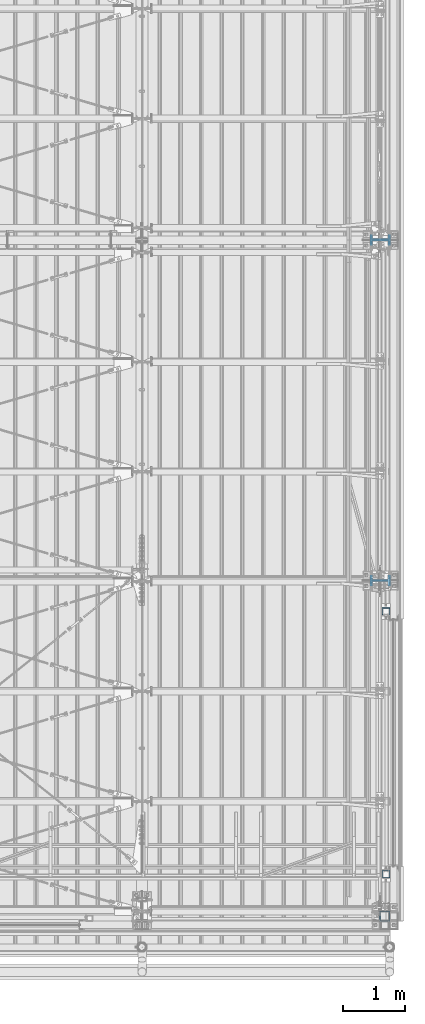
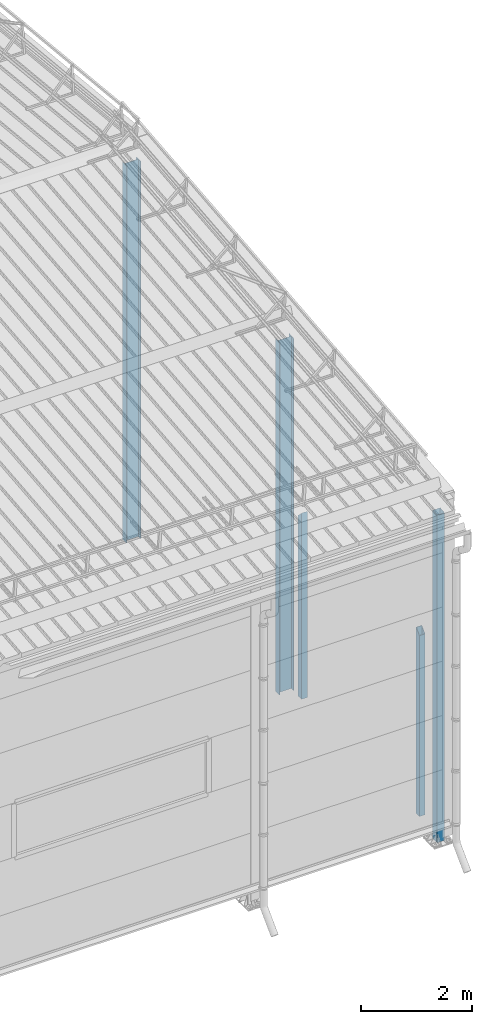
# One storey, part 236 of 709: 5 columns, 1 opening, 5 elements without a shape of their own.
"""IFC4 building model written with IfcOpenShell, lengths in millimetres."""

import ifcopenshell
import ifcopenshell.guid

model = None  # the IFC model being written
_history = None  # IfcOwnerHistory: only IFC2X3 demands one
_inside = {}  # id of a spatial element -> (the spatial element, [elements in it])
_under = {}  # id of a project, library or spatial element -> (it, [spatial elements below it])
_declared = {}  # id of a project -> (the project, [libraries it declares])
_typed = {}  # id of a type object -> (the type object, [elements of that type])
_made_of = {}  # id of a material, layer set ... -> (it, [elements and type objects made of it])


def new_model(schema):
    """Start an empty IFC model of exactly this schema.

    Asked for "IFC4X3", IfcOpenShell would pick the latest addendum, in which some entities
    have other attributes; the version numbers below select the first issue.
    IFC2X3 requires an IfcOwnerHistory on every rooted entity: one is made here for all.
    """
    global model, _history
    if schema == "IFC4X3":
        model = ifcopenshell.file(schema_version=(4, 3, 0, 0))
    else:
        model = ifcopenshell.file(schema=schema)
    _inside.clear()
    _under.clear()
    _declared.clear()
    _typed.clear()
    _made_of.clear()
    _history = None
    if model.schema == "IFC2X3":
        org = make("IfcOrganization", Name="unknown")
        user = make(
            "IfcPersonAndOrganization",
            ThePerson=make("IfcPerson", FamilyName="unknown"),
            TheOrganization=org,
        )
        app = make(
            "IfcApplication",
            ApplicationDeveloper=org,
            Version="unknown",
            ApplicationFullName="unknown",
            ApplicationIdentifier="unknown",
        )
        _history = make(
            "IfcOwnerHistory",
            OwningUser=user,
            OwningApplication=app,
            ChangeAction="ADDED",
            CreationDate=0,
        )
    return model


def make(cls, **values):
    """One entity of the class cls with the attributes given. An attribute that is None is left unset."""
    return model.create_entity(
        cls, **{name: value for name, value in values.items() if value is not None}
    )


def rooted(cls, **values):
    """An entity with a GlobalId (a new one), such as an element, a storey or a relation."""
    return make(cls, GlobalId=ifcopenshell.guid.new(), OwnerHistory=_history, **values)


def si_unit(unit_type, name, prefix=None):
    """IfcSIUnit, for example si_unit("LENGTHUNIT", "METRE", prefix="MILLI")."""
    return make("IfcSIUnit", UnitType=unit_type, Prefix=prefix, Name=name)


def assignment(units):
    """IfcUnitAssignment: the units of a project."""
    return None if units is None else make("IfcUnitAssignment", Units=units)


def point(xyz):
    """IfcCartesianPoint."""
    return None if xyz is None else make("IfcCartesianPoint", Coordinates=xyz)


def direction(xyz):
    """IfcDirection."""
    return None if xyz is None else make("IfcDirection", DirectionRatios=xyz)


def frame(location, z_axis=None, x_axis=None):
    """IfcAxis2Placement3D, a coordinate frame: its origin and axes. An axis left out is left unset."""
    return make(
        "IfcAxis2Placement3D",
        Location=point(location),
        Axis=direction(z_axis),
        RefDirection=direction(x_axis),
    )


def origin_with_axes():
    """The frame at (0, 0, 0) with the z axis (0, 0, 1) and the x axis (1, 0, 0) written out."""
    return frame((0.0, 0.0, 0.0), z_axis=(0.0, 0.0, 1.0), x_axis=(1.0, 0.0, 0.0))


def place(relative_to, where):
    """IfcLocalPlacement: puts the frame where relative to a parent placement (None: the world)."""
    return make(
        "IfcLocalPlacement", PlacementRelTo=relative_to, RelativePlacement=where
    )


def context(
    kind, dimensions, precision=None, world=None, true_north=None, identifier=None
):
    """IfcGeometricRepresentationContext, for example the 3D "Model" context."""
    return make(
        "IfcGeometricRepresentationContext",
        ContextIdentifier=identifier,
        ContextType=kind,
        CoordinateSpaceDimension=dimensions,
        Precision=precision,
        WorldCoordinateSystem=world,
        TrueNorth=true_north,
    )


def subcontext(parent, identifier, kind, view, scale=None):
    """IfcGeometricRepresentationSubContext, for example "Body" below "Model"."""
    return make(
        "IfcGeometricRepresentationSubContext",
        ContextIdentifier=identifier,
        ContextType=kind,
        ParentContext=parent,
        TargetScale=scale,
        TargetView=view,
    )


def project(units=None, contexts=None):
    """IfcProject with its units and contexts."""
    return rooted(
        "IfcProject",
        Name="project",
        RepresentationContexts=contexts,
        UnitsInContext=assignment(units),
    )


def spatial(cls, under=None, at=None, **own):
    """A site, building, storey or space (cls), placed at a placement, below another one or the project."""
    s = rooted(cls, ObjectPlacement=at, **own)
    if under is not None:
        _under.setdefault(under.id(), (under, []))[1].append(s)
    return s


def point_list(points):
    """IfcCartesianPointList2D or 3D."""
    cls = (
        "IfcCartesianPointList2D" if len(points[0]) == 2 else "IfcCartesianPointList3D"
    )
    return make(cls, CoordList=points)


def line(*indices):
    """IfcLineIndex: a straight run through numbered points of an indexed curve."""
    return model.create_entity("IfcLineIndex", indices)


def indexed_curve(points, segments=None, self_intersect=None):
    """IfcIndexedPolyCurve: lines and arcs through numbered points (the first is 1)."""
    return make(
        "IfcIndexedPolyCurve",
        Points=point_list(points),
        Segments=segments,
        SelfIntersect=self_intersect,
    )


def outline(outer, holes=None, kind="AREA"):
    """IfcArbitraryClosedProfileDef: a profile drawn as a closed curve; with holes, ...WithVoids."""
    if holes is None:
        return make("IfcArbitraryClosedProfileDef", ProfileType=kind, OuterCurve=outer)
    return make(
        "IfcArbitraryProfileDefWithVoids",
        ProfileType=kind,
        OuterCurve=outer,
        InnerCurves=holes,
    )


def extrude(swept, where, along, depth):
    """IfcExtrudedAreaSolid: the profile swept, set in the frame where, extruded along a direction by depth."""
    return make(
        "IfcExtrudedAreaSolid",
        SweptArea=swept,
        Position=where,
        ExtrudedDirection=direction(along),
        Depth=depth,
    )


def polygons(points, faces, closed=None, point_numbers=None):
    """IfcPolygonalFaceSet: a face is its outer loop, then its inner loops; points numbered from 1."""
    made = []
    for loops in faces:
        if len(loops) == 1:
            made.append(make("IfcIndexedPolygonalFace", CoordIndex=loops[0]))
        else:
            made.append(
                make(
                    "IfcIndexedPolygonalFaceWithVoids",
                    CoordIndex=loops[0],
                    InnerCoordIndices=loops[1:],
                )
            )
    return make(
        "IfcPolygonalFaceSet",
        Coordinates=point_list(points),
        Closed=closed,
        Faces=made,
        PnIndex=point_numbers,
    )


def shape(context_of_items, identifier, shape_type, items):
    """IfcShapeRepresentation: the items that make up one representation, for example the "Body"."""
    return make(
        "IfcShapeRepresentation",
        ContextOfItems=context_of_items,
        RepresentationIdentifier=identifier,
        RepresentationType=shape_type,
        Items=items,
    )


def material(Name=None, Category=None):
    """IfcMaterial."""
    return make("IfcMaterial", Name=Name, Category=Category)


def made_of(thing, what):
    """Note that an element or type object is made of a material, layer set ...; save() writes the relation."""
    if what is not None:
        _made_of.setdefault(what.id(), (what, []))[1].append(thing)
    return thing


def element(
    cls,
    number,
    at=None,
    inside=None,
    cuts=None,
    type_object=None,
    material=None,
    context=None,
    identifier="Body",
    shape_type=None,
    held_by="IfcProductDefinitionShape",
    body=None,
    shapes=None,
    **own,
):
    """One element of the class cls, such as IfcWall. Its Tag is "e" and its number.

    at: its placement. inside: the storey or other place that contains it. cuts: it is an
    opening in that element (IfcRelVoidsElement). A single representation is given by context,
    identifier, shape_type and body (its items); several are given by shapes. held_by: the class
    of the entity that holds the representations. save() writes the other relations.
    """
    e = rooted(cls, Tag="e%d" % number, ObjectPlacement=at, **own)
    if body is not None:
        shapes = [shape(context, identifier, shape_type, body)]
    if shapes is not None:
        e.Representation = make(held_by, Representations=shapes)
    if inside is not None:
        _inside.setdefault(inside.id(), (inside, []))[1].append(e)
    if cuts is not None:
        rooted(
            "IfcRelVoidsElement", RelatingBuildingElement=cuts, RelatedOpeningElement=e
        )
    if type_object is not None:
        _typed.setdefault(type_object.id(), (type_object, []))[1].append(e)
    return made_of(e, material)


def aggregate(whole, parts):
    """IfcRelAggregates: a whole, such as a stair, and the parts it consists of."""
    return rooted("IfcRelAggregates", RelatingObject=whole, RelatedObjects=parts)


def save(model, path):
    """Write the relations noted so far, then the file.

    IfcRelAggregates (storeys below a building ...), IfcRelContainedInSpatialStructure (elements
    in a storey), IfcRelDefinesByType, IfcRelAssociatesMaterial and IfcRelDeclares: one each for
    every whole, place, type object, material and project.
    """
    for whole, parts in _under.values():
        aggregate(whole, parts)
    for where, things in _inside.values():
        rooted(
            "IfcRelContainedInSpatialStructure",
            RelatedElements=things,
            RelatingStructure=where,
        )
    for kind, things in _typed.values():
        rooted("IfcRelDefinesByType", RelatedObjects=things, RelatingType=kind)
    for what, things in _made_of.values():
        rooted("IfcRelAssociatesMaterial", RelatedObjects=things, RelatingMaterial=what)
    for by, libraries in _declared.values():
        rooted("IfcRelDeclares", RelatingContext=by, RelatedDefinitions=libraries)
    model.write(path)


model = new_model("IFC4")

# Units and contexts
model_context = context("Model", 3, precision=0.2, world=origin_with_axes(), true_north=direction((0.0, 1.0)))
body_context = subcontext(model_context, "Body", "Model", "MODEL_VIEW")
reference_context = subcontext(model_context, "Reference", "Model", "MODEL_VIEW")
ifc_project = project(units=[si_unit("LENGTHUNIT", "METRE", prefix="MILLI"), si_unit("AREAUNIT", "SQUARE_METRE"), si_unit("VOLUMEUNIT", "CUBIC_METRE"), si_unit("MASSUNIT", "GRAM", prefix="KILO"), si_unit("TIMEUNIT", "SECOND"), si_unit("PLANEANGLEUNIT", "RADIAN"), si_unit("SOLIDANGLEUNIT", "STERADIAN"), si_unit("THERMODYNAMICTEMPERATUREUNIT", "DEGREE_CELSIUS"), si_unit("LUMINOUSINTENSITYUNIT", "LUMEN")], contexts=[model_context])

# Site, building, storey
site_placement = place(None, origin_with_axes())
site = spatial("IfcSite", under=ifc_project, at=site_placement, CompositionType="ELEMENT")
building_placement = place(site_placement, origin_with_axes())
building = spatial("IfcBuilding", under=site, at=building_placement, Name="Undefined", CompositionType="ELEMENT")
storey_placement = place(building_placement, origin_with_axes())
storey = spatial("IfcBuildingStorey", under=building, at=storey_placement, Name="Undefined", CompositionType="ELEMENT", Elevation=0.0)

# Assembly, column
assembly_1_placement = place(storey_placement, frame((49851.0, 5500.0, -200.0), z_axis=(0.0, -1.0, 0.0), x_axis=(0.0, 0.0, 1.0)))
assembly_1 = element("IfcElementAssembly", 1, at=assembly_1_placement, inside=storey)
ifc_material_1 = material(Name="C255-4", Category="STEEL")
column_1_placement = place(assembly_1_placement, origin_with_axes())
column_1 = element("IfcColumn", 2, at=column_1_placement, material=ifc_material_1, ObjectType="414", context=body_context, shape_type="Tessellation", body=[
    polygons([(25.0, -149.0, -74.5), (25.0, -141.0, -74.5), (7765.31561, -141.0, -74.5), (7765.31561, -149.0, -74.5), (25.0, -141.0, -2.75), (7758.14061, -141.0, -2.75), (25.0, 141.0, -2.75), (7758.14061, 141.0, -2.75), (25.0, 141.0, -74.5), (7765.31561, 141.0, -74.5), (25.0, 149.0, -74.5), (7765.31561, 149.0, -74.5), (25.0, 149.0, 74.5), (7750.41561, 149.0, 74.5), (25.0, 141.0, 74.5), (7750.41561, 141.0, 74.5), (25.0, 141.0, 2.75), (7757.59061, 141.0, 2.75), (25.0, -141.0, 2.75), (7757.59061, -141.0, 2.75), (25.0, -141.0, 74.5), (7750.41561, -141.0, 74.5), (25.0, -149.0, 74.5), (7750.41561, -149.0, 74.5)], [[[1, 2, 3, 4]], [[2, 5, 6, 3]], [[5, 7, 8, 6]], [[7, 9, 10, 8]], [[9, 11, 12, 10]], [[11, 13, 14, 12]], [[13, 15, 16, 14]], [[15, 17, 18, 16]], [[17, 19, 20, 18]], [[19, 21, 22, 20]], [[21, 23, 24, 22]], [[23, 1, 4, 24]], [[6, 8, 10, 12, 14, 16, 18, 20, 22, 24, 4, 3]], [[23, 21, 19, 17, 15, 13, 11, 9, 7, 5, 2, 1]]], closed=True),
])
aggregate(assembly_1, [column_1])

assembly_2_placement = place(storey_placement, frame((49920.0, 80.0, -200.0), z_axis=(0.0, -1.0, 0.0), x_axis=(0.0, 0.0, 1.0)))
assembly_2 = element("IfcElementAssembly", 3, at=assembly_2_placement, inside=storey)
column_2_placement = place(assembly_2_placement, origin_with_axes())
column_2 = element("IfcColumn", 4, at=column_2_placement, material=ifc_material_1, ObjectType="412", context=body_context, shape_type="Tessellation", body=[
    polygons([(25.0, -74.0, -74.0), (25.0, -74.0, 74.0), (7212.48556, -74.0, 74.0), (7227.28556, -74.0, -74.0), (25.0, 74.0, 74.0), (7212.48556, 74.0, 74.0), (25.0, 74.0, -74.0), (7227.28556, 74.0, -74.0), (25.0, -80.0, -80.0), (25.0, 80.0, -80.0), (7227.88556, 80.0, -80.0), (7227.88556, -80.0, -80.0), (25.0, 80.0, 80.0), (7211.88556, 80.0, 80.0), (25.0, -80.0, 80.0), (7211.88556, -80.0, 80.0)], [[[1, 2, 3, 4]], [[2, 5, 6, 3]], [[5, 7, 8, 6]], [[7, 1, 4, 8]], [[9, 10, 11, 12]], [[10, 13, 14, 11]], [[13, 15, 16, 14]], [[15, 9, 12, 16]], [[14, 16, 12, 11], [6, 8, 4, 3]], [[15, 13, 10, 9], [7, 5, 2, 1]]], closed=True),
])
aggregate(assembly_2, [column_2])

assembly_3_placement = place(storey_placement, frame((49940.0, 760.0, -50.0), z_axis=(0.0, 1.0, 0.0), x_axis=(0.0, 0.0, 1.0)))
assembly_3 = element("IfcElementAssembly", 5, at=assembly_3_placement, inside=storey)
ifc_material_2 = material(Name="C255", Category="STEEL")
column_3_placement = place(assembly_3_placement, origin_with_axes())
column_3 = element("IfcColumn", 6, at=column_3_placement, material=ifc_material_2, ObjectType="530", context=body_context, shape_type="Tessellation", body=[
    polygons([(12.0, -60.0, 60.0), (12.0, -60.0, -60.0), (3980.0, -60.0, -60.0), (4100.0, -60.0, 60.0), (12.0, 60.0, 60.0), (4100.0, 60.0, 60.0), (12.0, 60.0, -60.0), (3980.0, 60.0, -60.0), (12.0, -56.0, 56.0), (12.0, 56.0, 56.0), (4096.0, 56.0, 56.0), (4096.0, -56.0, 56.0), (12.0, -56.0, -56.0), (3984.0, -56.0, -56.0), (12.0, 56.0, -56.0), (3984.0, 56.0, -56.0)], [[[1, 2, 3, 4]], [[5, 1, 4, 6]], [[7, 5, 6, 8]], [[2, 7, 8, 3]], [[1, 5, 7, 2], [15, 10, 9, 13]], [[9, 10, 11, 12]], [[13, 9, 12, 14]], [[15, 13, 14, 16]], [[10, 15, 16, 11]], [[3, 8, 6, 4], [14, 12, 11, 16]]], closed=True),
])
aggregate(assembly_3, [column_3])

assembly_4_placement = place(storey_placement, frame((49940.0, 5000.0, -50.0), z_axis=(0.0, 1.0, 0.0), x_axis=(0.0, 0.0, 1.0)))
assembly_4 = element("IfcElementAssembly", 7, at=assembly_4_placement, inside=storey)
column_4_placement = place(assembly_4_placement, origin_with_axes())
column_4 = element("IfcColumn", 8, at=column_4_placement, material=ifc_material_2, ObjectType="530", context=body_context, shape_type="Tessellation", body=[
    polygons([(12.0, -60.0, 60.0), (12.0, -60.0, -60.0), (4100.0, -60.0, -60.0), (3980.0, -60.0, 60.0), (12.0, 60.0, 60.0), (3980.0, 60.0, 60.0), (12.0, 60.0, -60.0), (4100.0, 60.0, -60.0), (12.0, 56.0, 56.0), (12.0, 56.0, -56.0), (4096.0, 56.0, -56.0), (3984.0, 56.0, 56.0), (12.0, -56.0, 56.0), (3984.0, -56.0, 56.0), (12.0, -56.0, -56.0), (4096.0, -56.0, -56.0)], [[[1, 2, 3, 4]], [[5, 1, 4, 6]], [[7, 5, 6, 8]], [[2, 7, 8, 3]], [[1, 5, 7, 2], [10, 9, 13, 15]], [[9, 10, 11, 12]], [[13, 9, 12, 14]], [[15, 13, 14, 16]], [[10, 15, 16, 11]], [[4, 3, 8, 6], [14, 12, 11, 16]]], closed=True),
])
aggregate(assembly_4, [column_4])

# Assembly, column, voiding feature
assembly_5_placement = place(storey_placement, frame((49851.0, 11000.0, -200.0), z_axis=(0.0, -1.0, 0.0), x_axis=(0.0, 0.0, 1.0)))
assembly_5 = element("IfcElementAssembly", 9, at=assembly_5_placement, inside=storey)
column_5_placement = place(assembly_5_placement, origin_with_axes())
column_5 = element("IfcColumn", 10, at=column_5_placement, material=ifc_material_1, ObjectType="415", context=body_context, shape_type="Tessellation", body=[
    polygons([(8307.86561, 149.0, 0.0), (8307.86561, -149.0, 0.0), (8300.41561, -149.0, -74.5), (8300.41561, -141.0, -74.5), (8307.59061, -141.0, -2.75), (8307.59061, 141.0, -2.75), (8300.41561, 141.0, -74.5), (8300.41561, 149.0, -74.5), (8300.41561, 149.0, 74.5), (8300.41561, 141.0, 74.5), (8307.59061, 141.0, 2.75), (8307.59061, -141.0, 2.75), (8300.41561, -141.0, 74.5), (8300.41561, -149.0, 74.5), (25.0, -149.0, 74.5), (25.0, -141.0, 74.5), (25.0, -141.0, 2.75), (25.0, 141.0, 2.75), (25.0, 141.0, 74.5), (25.0, 149.0, 74.5), (25.0, 149.0, -74.5), (25.0, 141.0, -74.5), (25.0, 141.0, -2.75), (25.0, -141.0, -2.75), (25.0, -141.0, -74.5), (25.0, -149.0, -74.5)], [[[1, 2, 3, 4, 5, 6, 7, 8]], [[9, 10, 11, 12, 13, 14, 2, 1]], [[15, 16, 17, 18, 19, 20, 21, 22, 23, 24, 25, 26]], [[22, 21, 8, 7]], [[23, 22, 7, 6]], [[24, 23, 6, 5]], [[25, 24, 5, 4]], [[26, 25, 4, 3]], [[15, 26, 3, 2, 14]], [[16, 15, 14, 13]], [[17, 16, 13, 12]], [[18, 17, 12, 11]], [[19, 18, 11, 10]], [[20, 19, 10, 9]], [[21, 20, 9, 1, 8]]], closed=True),
])
voiding_feature_placement = place(column_5_placement, frame((8307.86561, 0.0, 0.0), z_axis=(0.0, 1.0, 0.0), x_axis=(-0.099503719, 0.0, 0.9950371902)))
element("IfcVoidingFeature", 11, at=voiding_feature_placement, cuts=column_5, PredefinedType="HOLE", context=reference_context, identifier="Reference", shape_type="SolidModel", body=[
    extrude(outline(indexed_curve([(0.0, 0.0), (124.5, 0.0), (89.1068, 353.93201), (-157.42785, 329.27854), (-122.03465, -24.65347)], segments=[line(1, 2, 3, 4, 5, 1)])), frame((0.0, 0.0, 149.0), z_axis=(0.0, 0.0, 1.0), x_axis=(1.0, 0.0, 0.0)), (0.0, 0.0, -1.0), 298.0),
])
aggregate(assembly_5, [column_5])

save(model, "model.ifc")
